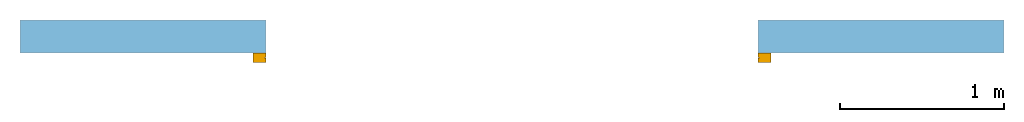
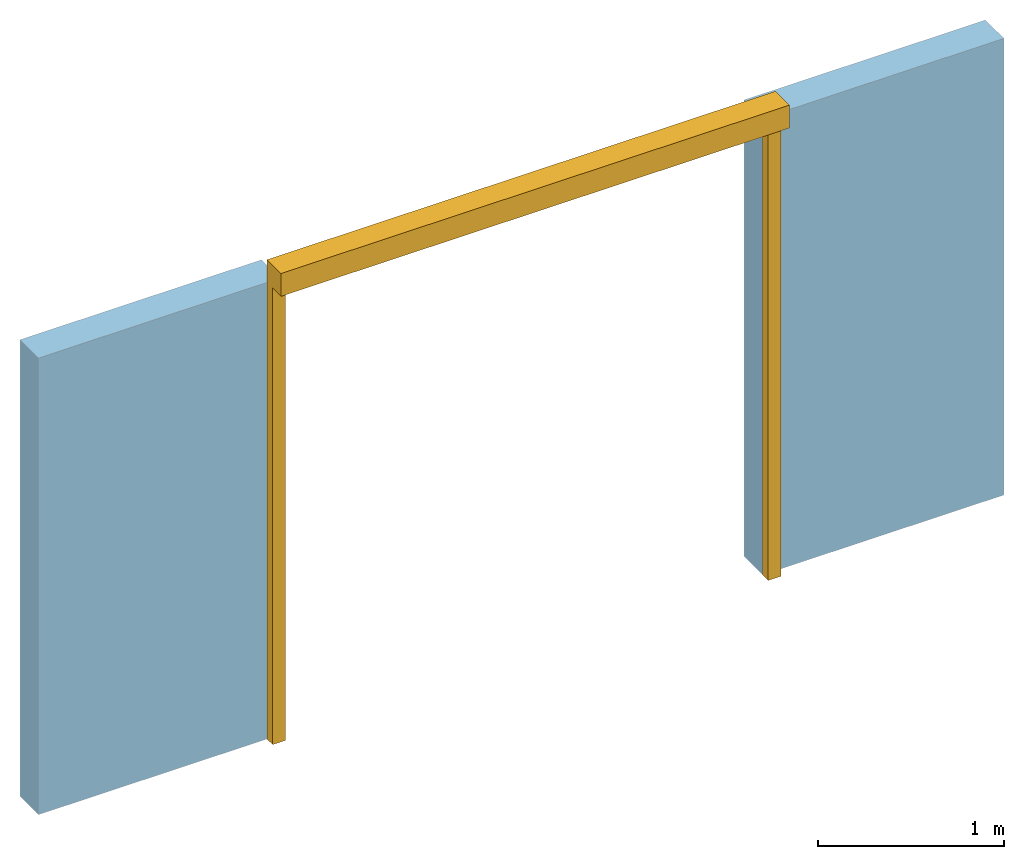
# One storey, part 2 of 2: 1 door, 1 opening, plus 1 element that does not belong to this part.
"""IFC2X3 building model written with IfcOpenShell, lengths in millimetres."""

from ifc_helpers import new_model, entity, si_unit, converted_unit, derived_unit, direction, frame, frame_2d, origin, place, context, subcontext, project, spatial, rectangle, extrude, faceted_brep, source, transform, mapped, material, layer, layer_set, layer_usage, type_object, type_shapes, element, fill, save


model = new_model("IFC2X3")

# Units and contexts
model_context = context("Model", 3, precision=0.01, world=origin(), true_north=direction((6.12303176911189e-17, 1.0)))
context_of_model = context(None, 3, precision=0.01, world=origin(), true_north=direction((6.12303176911189e-17, 1.0)))
body_context = subcontext(model_context, "Body", "Model", "MODEL_VIEW")
ifc_project = project(units=[si_unit("LENGTHUNIT", "METRE", prefix="MILLI"), si_unit("AREAUNIT", "SQUARE_METRE"), si_unit("VOLUMEUNIT", "CUBIC_METRE"), converted_unit("PLANEANGLEUNIT", "DEGREE", entity("IfcRatioMeasure", 0.0174532925199433), si_unit("PLANEANGLEUNIT", "RADIAN"), dimensions=[0, 0, 0, 0, 0, 0, 0]), si_unit("MASSUNIT", "GRAM", prefix="KILO"), si_unit("TIMEUNIT", "SECOND"), si_unit("FREQUENCYUNIT", "HERTZ"), si_unit("THERMODYNAMICTEMPERATUREUNIT", "DEGREE_CELSIUS"), derived_unit("THERMALTRANSMITTANCEUNIT", [(si_unit("MASSUNIT", "GRAM", prefix="KILO"), 1), (si_unit("THERMODYNAMICTEMPERATUREUNIT", "KELVIN"), -1), (si_unit("TIMEUNIT", "SECOND"), -3)]), derived_unit("VOLUMETRICFLOWRATEUNIT", [(si_unit("LENGTHUNIT", "METRE"), 3), (si_unit("TIMEUNIT", "SECOND"), -1)]), si_unit("ELECTRICCURRENTUNIT", "AMPERE"), si_unit("ELECTRICVOLTAGEUNIT", "VOLT"), si_unit("POWERUNIT", "WATT"), si_unit("FORCEUNIT", "NEWTON", prefix="KILO"), si_unit("ILLUMINANCEUNIT", "LUX"), si_unit("LUMINOUSFLUXUNIT", "LUMEN"), si_unit("LUMINOUSINTENSITYUNIT", "CANDELA"), si_unit("PRESSUREUNIT", "PASCAL")], contexts=[model_context, context_of_model])

# Site, building, storey
site_placement = place(None, origin())
site = spatial("IfcSite", under=ifc_project, at=site_placement, CompositionType="ELEMENT")
building_placement = place(site_placement, origin())
building = spatial("IfcBuilding", under=site, at=building_placement, CompositionType="ELEMENT")
storey_placement = place(building_placement, origin())
storey = spatial("IfcBuildingStorey", under=building, at=storey_placement, CompositionType="ELEMENT", Elevation=0.0)

# Wall, opening, door
ifc_material_1 = material()
ifc_layer = layer(ifc_material_1, 200.0)
ifc_layer_set = layer_set([ifc_layer])
ifc_layer_usage = layer_usage(ifc_layer_set, "AXIS2", "NEGATIVE", 100.0)
wall_type = type_object("IfcWallType", PredefinedType="STANDARD", material=ifc_layer_set)
wall_placement = place(storey_placement, frame((-30147.0958388037, 10047.082659008, 0.0)))
wall = element("IfcWallStandardCase", 1, at=wall_placement, inside=storey, type_object=wall_type, material=ifc_layer_usage, context=body_context, shape_type="SweptSolid", body=[
    extrude(rectangle(XDim=6000.0, YDim=199.999999999998, at=frame_2d((3000.0, 6.96331881044898e-13), x_axis=(-1.0, 0.0))), origin(), (0.0, 0.0, 1.0), 3000.0),
])
opening_placement = place(wall_placement, frame((1265.0, -250.0, 0.0)))
opening = element("IfcOpeningElement", 2, at=opening_placement, cuts=wall, ObjectType="Opening", context=body_context, shape_type="Brep", body=[
    faceted_brep([(3235.0, 150.0, 3000.0), (3235.0, 350.0, 3000.0), (235.0, 350.0, 3000.0), (235.0, 150.0, 3000.0), (0.0, 150.0, 3000.0), (0.0, 0.0, 3000.0), (3420.0, 0.0, 3000.0), (3420.0, 150.0, 3000.0), (3235.0, 150.0, 0.0), (3420.0, 150.0, 0.0), (3420.0, 0.0, 0.0), (0.0, 0.0, 0.0), (0.0, 150.0, 0.0), (235.0, 150.0, 0.0), (235.0, 350.0, 0.0), (3235.0, 350.0, 0.0)], [[[0, 1, 2, 3, 4, 5, 6, 7]], [[8, 9, 10, 11, 12, 13, 14, 15]], [[1, 0, 8, 15]], [[2, 1, 15, 14]], [[3, 2, 14, 13]], [[4, 3, 13, 12]], [[5, 4, 12, 11]], [[6, 5, 11, 10]], [[7, 6, 10, 9]], [[0, 7, 9, 8]]]),
])
ifc_material_2 = material()
door_style = type_object("IfcDoorStyle", ConstructionType="NOTDEFINED", OperationType="NOTDEFINED", ParameterTakesPrecedence=False, Sizeable=False, material=ifc_material_2)
shared_shape = source(origin(), body_context, "Body", "Brep", [
    faceted_brep([(3185.0, 260.0, 0.0), (3265.0, 260.0, 0.0), (3265.0, 200.0, 0.0), (3185.0, 200.0, 0.0), (3185.0, 230.0, 0.0), (3195.0, 230.0, 0.0), (3195.0, 231.0, 0.0), (3185.0, 231.0, 0.0), (3185.0, 260.0, 3000.0), (3265.0, 260.0, 3000.0), (3265.0, 350.0, 3000.0), (3265.0, 350.0, 3150.0), (3265.0, 200.0, 3150.0), (105.0, 200.0, 3150.0), (105.0, 200.0, 0.0), (185.0, 200.0, 0.0), (185.0, 200.0, 3000.0), (3185.0, 200.0, 3000.0), (3185.0, 230.0, 3000.0), (3195.0, 230.0, 3000.0), (3195.0, 231.0, 3000.0), (3185.0, 231.0, 3000.0), (105.0, 350.0, 3150.0), (105.0, 350.0, 3000.0), (185.0, 230.0, 3000.0), (175.0, 230.0, 3000.0), (175.0, 231.0, 3000.0), (185.0, 231.0, 3000.0), (185.0, 260.0, 3000.0), (105.0, 260.0, 3000.0), (105.0, 260.0, 0.0), (185.0, 260.0, 0.0), (185.0, 231.0, 0.0), (175.0, 231.0, 0.0), (175.0, 230.0, 0.0), (185.0, 230.0, 0.0)], [[[0, 1, 2, 3, 4, 5, 6, 7]], [[1, 0, 8, 9]], [[2, 1, 9, 10, 11, 12]], [[3, 2, 12, 13, 14, 15, 16, 17]], [[4, 3, 17, 18]], [[5, 4, 18, 19]], [[6, 5, 19, 20]], [[7, 6, 20, 21]], [[0, 7, 21, 8]], [[11, 22, 13, 12]], [[23, 10, 9, 8, 21, 20, 19, 18, 17, 16, 24, 25, 26, 27, 28, 29]], [[22, 11, 10, 23]], [[14, 13, 22, 23, 29, 30]], [[31, 32, 33, 34, 35, 15, 14, 30]], [[31, 30, 29, 28]], [[15, 35, 24, 16]], [[35, 34, 25, 24]], [[34, 33, 26, 25]], [[33, 32, 27, 26]], [[32, 31, 28, 27]]]),
])
type_shapes(door_style, [shared_shape])
door_placement = place(opening_placement, frame((3420.0, 350.0, 0.0), z_axis=(0.0, 0.0, 1.0), x_axis=(-1.0, 0.0, 0.0)))
door = element("IfcDoor", 3, at=door_placement, inside=storey, type_object=door_style, material=ifc_material_2, OverallHeight=3149.99999999998, OverallWidth=3160.00000000001, context=body_context, shape_type="MappedRepresentation", body=[
    mapped(shared_shape, transform((0.0, 0.0, 0.0), scale=1.0)),
])
fill(opening, door)

save(model, "model.ifc")
